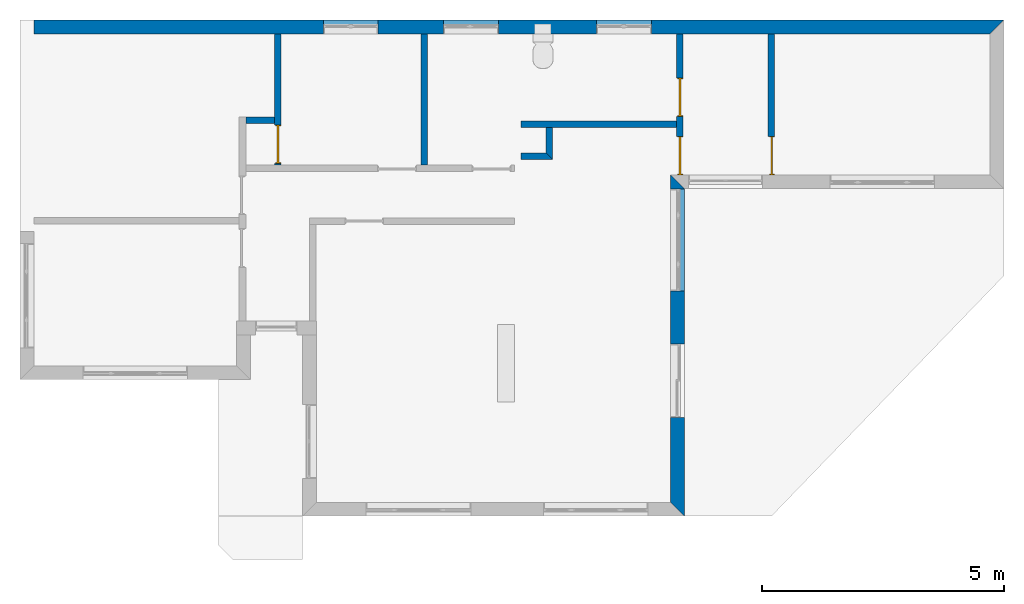
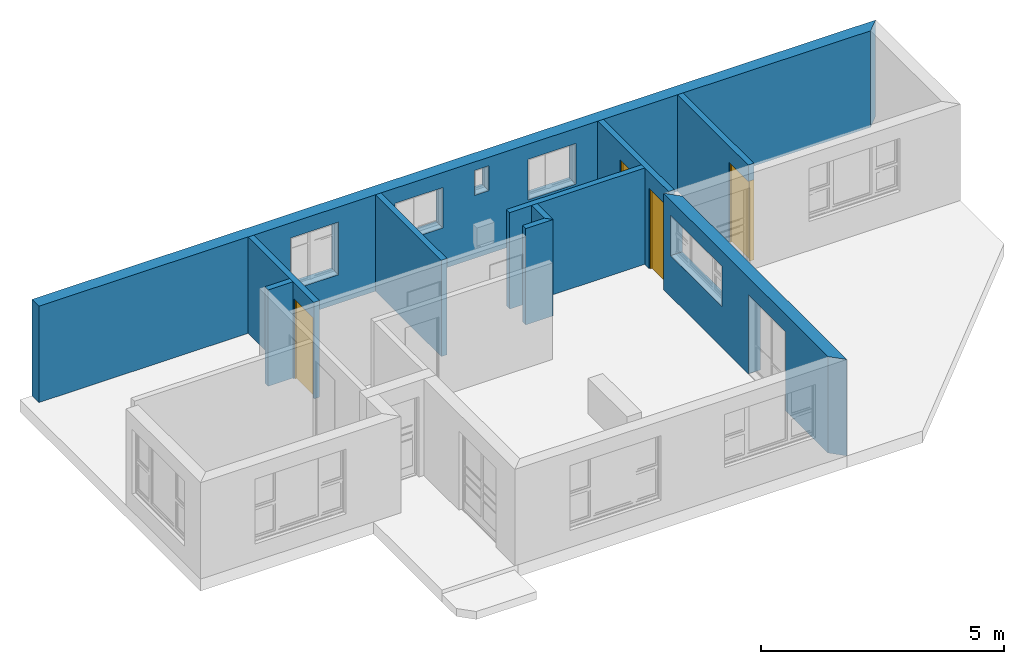
"""IFC4 building model written with IfcOpenShell, lengths in millimetres."""

from ifc_helpers import new_model, entity, si_unit, converted_unit, frame, origin_with_axes, origin_2d_with_axis, place, context, subcontext, project, spatial, line, indexed_curve, outline, extrude, clip, halfspace, polygons, source, transform, mapped, material, layer, layer_set, layer_usage, type_object, type_shapes, element, fill, save


model = new_model("IFC4")

# Units and contexts
model_context = context("Model", 3, precision=1e-05, world=origin_with_axes())
plan_context = context("Plan", 2, precision=1e-05, world=origin_2d_with_axis())
body_context = subcontext(model_context, "Body", "Model", "MODEL_VIEW")
ifc_project = project(units=[si_unit("VOLUMEUNIT", "CUBIC_METRE"), si_unit("LENGTHUNIT", "METRE", prefix="MILLI"), converted_unit("PLANEANGLEUNIT", "degree", entity("IfcReal", 0.0174532925199433), si_unit("PLANEANGLEUNIT", "RADIAN"), dimensions=[0, 0, 0, 0, 0, 0, 0]), si_unit("AREAUNIT", "SQUARE_METRE")], contexts=[model_context, plan_context])

# Site, building, storey
site_placement = place(None, origin_with_axes())
site = spatial("IfcSite", under=ifc_project, at=site_placement)
building_placement = place(site_placement, origin_with_axes())
building = spatial("IfcBuilding", under=site, at=building_placement, Name="Building")
storey_1_placement = place(building_placement, origin_with_axes())
storey_1 = spatial("IfcBuildingStorey", under=building, at=storey_1_placement, Name="EXISTING")

# Wall
ifc_material = material()
ifc_layer_1 = layer(ifc_material, 135.0)
ifc_layer_set_1 = layer_set([ifc_layer_1])
ifc_layer_usage_1 = layer_usage(ifc_layer_set_1, "AXIS2", "POSITIVE", 0.0)
wall_type_1 = type_object("IfcWallType", Name="WAL135", PredefinedType="NOTDEFINED", material=ifc_layer_set_1)
wall_1_placement = place(storey_1_placement, frame((10114.1204833984, 3521.66748046875, 0.0), z_axis=(0.0, 0.0, 1.0), x_axis=(0.999999999999993, 1.19209282445353e-07, 0.0)))
element("IfcWall", 1, at=wall_1_placement, inside=storey_1, type_object=wall_type_1, material=ifc_layer_usage_1, Name="Wall", context=body_context, shape_type="SweptSolid", body=[
    extrude(outline(indexed_curve([(0.0, 0.0), (0.0, 135.0), (3215.00111747473, 135.0), (3215.00111747473, 0.0), (0.0, 0.0)], self_intersect=False)), origin_with_axes(), (0.0, 0.0, 1.0), 2425.00019073486),
])

# Wall, opening, door
ifc_layer_usage_2 = layer_usage(ifc_layer_set_1, "AXIS2", "POSITIVE", 0.0)
wall_2_placement = place(storey_1_placement, frame((5009.11998748779, 5461.66658401489, 0.0), z_axis=(0.0, 0.0, 1.0), x_axis=(3.13916473260163e-07, -0.999999999999951, 0.0)))
wall_2 = element("IfcWall", 2, at=wall_2_placement, inside=storey_1, type_object=wall_type_1, material=ifc_layer_usage_2, Name="Wall", context=body_context, shape_type="SweptSolid", body=[
    extrude(outline(indexed_curve([(0.0, 0.0), (0.0, 135.0), (2715.00015357159, 135.0), (2715.00015357159, 0.0), (0.0, 0.0)], self_intersect=False)), origin_with_axes(), (0.0, 0.0, 1.0), 2425.00019073486),
])
shared_shape_1 = source(origin_with_axes(), body_context, "Body", "SweptSolid", [
    extrude(outline(indexed_curve([(0.0, 0.0), (800.001098632812, 0.0), (800.001098632812, 2015.00024414062), (0.0, 2015.00024414062)], segments=[line(1, 2, 3, 4, 1)])), frame((-1.78813922957488e-06, -600.0, 0.0), z_axis=(0.0, -1.0, 0.0), x_axis=(1.0, 0.0, 0.0)), (0.0, 0.0, -1.0), 1200.0),
])
opening_1_placement = place(wall_2_placement, frame((1885.00118255638, 0.000219627772857223, 0.0), z_axis=(0.0, 0.0, 1.0), x_axis=(1.0, 0.0, 0.0)))
opening_1 = element("IfcOpeningElement", 3, at=opening_1_placement, cuts=wall_2, Name="Opening", PredefinedType="OPENING", context=body_context, shape_type="MappedRepresentation", body=[
    mapped(shared_shape_1, transform((0.0, 0.0, 0.0), x_axis=(1.0, 0.0, 0.0), y_axis=(0.0, 1.0, 0.0), z_axis=(0.0, 0.0, 1.0), scale=1.0)),
])
door_type = type_object("IfcDoorType", OperationType="NOTDEFINED", PredefinedType="DOOR")
shared_shape_2 = source(origin_with_axes(), body_context, "Body", "Tessellation", [
    polygons([(0.000119209282274824, -53.7499732971191, 0.0), (20.0005760192871, -53.7499732971191, 0.0), (0.000119209282274824, -53.75, 1994.99987792969), (20.0005760192871, -53.75, 1994.99987792969), (0.000119209282274824, 56.2500038146973, 0.0), (20.0005760192871, 56.2500076293945, 0.0), (0.000119209282274824, 56.2499351501465, 1994.99987792969), (20.0005760192871, 56.249942779541, 1994.99987792969), (799.999328613281, -53.7499656677246, 1994.99987792969), (-0.0017881392268464, -53.75, 1994.99987792969), (799.999328613281, -53.7499656677246, 2015.00024414062), (799.999328613281, 56.2499809265137, 1994.99987792969), (-0.0017881392268464, 56.2499351501465, 1994.99987792969), (799.999328613281, 56.2499809265137, 2015.00024414062), (-0.0017881392268464, 56.2499351501465, 2014.99975585938), (-0.0017881392268464, -53.75, 2014.99975585938), (779.996948242188, -53.7499656677246, 0.0), (779.996948242188, -53.7499923706055, 1994.99987792969), (799.999328613281, -53.7499656677246, 0.0), (779.996948242188, 56.2499771118164, 0.0), (779.996948242188, 56.249942779541, 1994.99987792969), (799.999328613281, 56.2499809265137, 0.0), (799.999328613281, 56.2499465942383, 1994.99987792969), (799.999328613281, -53.7499923706055, 1994.99987792969), (779.998840332031, -23.7499713897705, 1994.99987792969), (779.996948242188, -23.749942779541, 9.99998950958252), (19.9986686706543, -23.749979019165, 1994.99987792969), (779.998840332031, 16.2500343322754, 1994.99987792969), (779.996948242188, 16.2500343322754, 9.99998950958252), (19.9986686706543, 16.2500305175781, 1994.99987792969), (19.9967613220215, 16.2500305175781, 9.99998950958252), (19.9967613220215, -23.7499465942383, 9.99998950958252)], [[[1, 2, 4, 3]], [[3, 4, 8, 7]], [[7, 8, 6, 5]], [[5, 6, 2, 1]], [[3, 7, 5, 1]], [[8, 4, 2, 6]], [[10, 13, 12, 9]], [[9, 11, 16, 10]], [[12, 14, 11, 9]], [[13, 15, 14, 12]], [[15, 16, 11, 14]], [[10, 16, 15, 13]], [[18, 21, 20, 17]], [[17, 19, 24, 18]], [[20, 22, 19, 17]], [[21, 23, 22, 20]], [[23, 24, 19, 22]], [[18, 24, 23, 21]], [[26, 29, 28, 25]], [[25, 27, 32, 26]], [[28, 30, 27, 25]], [[29, 31, 30, 28]], [[31, 32, 27, 30]], [[26, 32, 31, 29]]], closed=True),
])
type_shapes(door_type, [shared_shape_2])
door_1_placement = place(opening_1_placement, frame((2.47210905079953e-05, 78.7507526651812, 0.0), z_axis=(0.0, 0.0, 1.0), x_axis=(0.999999999999886, -4.76837158203095e-07, 0.0)))
door_1 = element("IfcDoor", 4, at=door_1_placement, inside=storey_1, type_object=door_type, Name="Door", context=body_context, shape_type="MappedRepresentation", body=[
    mapped(shared_shape_2, transform((0.0, 0.0, 0.0), x_axis=(1.0, 0.0, 0.0), y_axis=(0.0, 1.0, 0.0), z_axis=(0.0, 0.0, 1.0), scale=1.0)),
])
fill(opening_1, door_1)

# Wall
ifc_layer_usage_3 = layer_usage(ifc_layer_set_1, "AXIS2", "POSITIVE", 0.0)
wall_3_placement = place(storey_1_placement, frame((8039.11972045898, 5461.66706085205, 0.0), z_axis=(0.0, 0.0, 1.0), x_axis=(3.13916473260163e-07, -0.999999999999951, 0.0)))
element("IfcWall", 5, at=wall_3_placement, inside=storey_1, type_object=wall_type_1, material=ifc_layer_usage_3, Name="Wall", context=body_context, shape_type="SweptSolid", body=[
    extrude(outline(indexed_curve([(0.0, 0.0), (0.0, 135.0), (2715.00015357159, 135.0), (2715.00015357159, 0.0), (0.0, 0.0)], self_intersect=False)), origin_with_axes(), (0.0, 0.0, 1.0), 2425.00019073486),
])

# Wall, openings
ifc_layer_usage_4 = layer_usage(ifc_layer_set_1, "AXIS2", "POSITIVE", 0.0)
wall_4_placement = place(storey_1_placement, frame((13329.119682312, 5461.66706085205, 0.0), z_axis=(0.0, 0.0, 1.0), x_axis=(3.13916473260163e-07, -0.999999999999951, 0.0)))
wall_4 = element("IfcWall", 6, at=wall_4_placement, inside=storey_1, type_object=wall_type_1, material=ifc_layer_usage_4, Name="Wall", context=body_context, shape_type="SweptSolid", body=[
    extrude(outline(indexed_curve([(0.0, 0.0), (0.0, 135.0), (2920.00009693527, 135.0), (2920.00009693527, 0.0), (0.0, 0.0)], self_intersect=False)), origin_with_axes(), (0.0, 0.0, 1.0), 2425.00019073486),
])
opening_2_placement = place(wall_4_placement, frame((2120.00086789768, 73.6082881344458, 0.0), z_axis=(0.0, 0.0, 1.0), x_axis=(1.0, 0.0, 0.0)))
opening_2 = element("IfcOpeningElement", 7, at=opening_2_placement, cuts=wall_4, Name="Opening", PredefinedType="OPENING", context=body_context, shape_type="MappedRepresentation", body=[
    mapped(shared_shape_1, transform((0.0, 0.0, 0.0), x_axis=(1.0, 0.0, 0.0), y_axis=(0.0, 1.0, 0.0), z_axis=(0.0, 0.0, 1.0), scale=1.0)),
])
opening_3_placement = place(wall_4_placement, frame((915.003807216657, 78.7497771987811, 0.0), z_axis=(0.0, 0.0, 1.0), x_axis=(1.0, 0.0, 0.0)))
opening_3 = element("IfcOpeningElement", 8, at=opening_3_placement, cuts=wall_4, Name="Opening", PredefinedType="OPENING", context=body_context, shape_type="MappedRepresentation", body=[
    mapped(shared_shape_1, transform((0.0, 0.0, 0.0), x_axis=(1.0, 0.0, 0.0), y_axis=(0.0, 1.0, 0.0), z_axis=(0.0, 0.0, 1.0), scale=1.0)),
])

# Storey
storey_2_placement = place(building_placement, origin_with_axes())
storey_2 = spatial("IfcBuildingStorey", under=building, at=storey_2_placement, Name="DEMO")

# Door
door_2_placement = place(opening_2_placement, frame((0.000948117118149128, 0.000398473892104789, 0.0), z_axis=(0.0, 0.0, 1.0), x_axis=(0.999999999999886, -4.76837158203095e-07, 0.0)))
door_2 = element("IfcDoor", 9, at=door_2_placement, inside=storey_2, type_object=door_type, Name="Door", context=body_context, shape_type="MappedRepresentation", body=[
    mapped(shared_shape_2, transform((0.0, 0.0, 0.0), x_axis=(1.0, 0.0, 0.0), y_axis=(0.0, 1.0, 0.0), z_axis=(0.0, 0.0, 1.0), scale=1.0)),
])

fill(opening_2, door_2)

door_3_placement = place(opening_3_placement, frame((0.000947729319911161, 0.00149959204698291, 0.0), z_axis=(0.0, 0.0, 1.0), x_axis=(0.999999999999886, -4.76837158203095e-07, 0.0)))
door_3 = element("IfcDoor", 10, at=door_3_placement, inside=storey_1, type_object=door_type, Name="Door", context=body_context, shape_type="MappedRepresentation", body=[
    mapped(shared_shape_2, transform((0.0, 0.0, 0.0), x_axis=(1.0, 0.0, 0.0), y_axis=(0.0, 1.0, 0.0), z_axis=(0.0, 0.0, 1.0), scale=1.0)),
])

fill(opening_3, door_3)

# Wall, opening, door
ifc_layer_usage_5 = layer_usage(ifc_layer_set_1, "AXIS2", "POSITIVE", 0.0)
wall_5_placement = place(storey_1_placement, frame((15224.1201400757, 5461.66706085205, 0.0), z_axis=(0.0, 0.0, 1.0), x_axis=(3.13916473260163e-07, -0.999999999999951, 0.0)))
wall_5 = element("IfcWall", 11, at=wall_5_placement, inside=storey_1, type_object=wall_type_1, material=ifc_layer_usage_5, Name="Wall", context=body_context, shape_type="SweptSolid", body=[
    extrude(outline(indexed_curve([(0.0, 0.0), (0.0, 135.0), (2920.00009693527, 135.0), (2920.00009693527, 0.0), (0.0, 0.0)], self_intersect=False)), origin_with_axes(), (0.0, 0.0, 1.0), 2425.00019073486),
])
opening_4_placement = place(wall_5_placement, frame((2120.00274658224, 0.000128114788111588, 0.0), z_axis=(0.0, 0.0, 1.0), x_axis=(1.0, 0.0, 0.0)))
opening_4 = element("IfcOpeningElement", 12, at=opening_4_placement, cuts=wall_5, Name="Opening", PredefinedType="OPENING", context=body_context, shape_type="MappedRepresentation", body=[
    mapped(shared_shape_1, transform((0.0, 0.0, 0.0), x_axis=(1.0, 0.0, 0.0), y_axis=(0.0, 1.0, 0.0), z_axis=(0.0, 0.0, 1.0), scale=1.0)),
])
door_4_placement = place(opening_4_placement, frame((0.00193206973220228, 78.7507704066837, 0.0), z_axis=(0.0, 0.0, 1.0), x_axis=(0.999999999999886, -4.76837158203095e-07, 0.0)))
door_4 = element("IfcDoor", 13, at=door_4_placement, inside=storey_1, type_object=door_type, Name="Door", context=body_context, shape_type="MappedRepresentation", body=[
    mapped(shared_shape_2, transform((0.0, 0.0, 0.0), x_axis=(1.0, 0.0, 0.0), y_axis=(0.0, 1.0, 0.0), z_axis=(0.0, 0.0, 1.0), scale=1.0)),
])
fill(opening_4, door_4)

# Walls
ifc_layer_usage_6 = layer_usage(ifc_layer_set_1, "AXIS2", "POSITIVE", 0.0)
wall_6_placement = place(storey_1_placement, frame((4419.11888122559, 3606.66704177856, 0.0), z_axis=(0.0, 0.0, 1.0), x_axis=(0.999999999999993, 1.19209282445353e-07, 0.0)))
element("IfcWall", 14, at=wall_6_placement, inside=storey_1, type_object=wall_type_1, material=ifc_layer_usage_6, Name="Wall", context=body_context, shape_type="SweptSolid", body=[
    extrude(outline(indexed_curve([(0.0, 0.0), (0.0, 135.0), (590.001571459213, 135.0), (590.001571459213, 0.0), (0.0, 0.0)], self_intersect=False)), origin_with_axes(), (0.0, 0.0, 1.0), 2425.00019073486),
])
ifc_layer_usage_7 = layer_usage(ifc_layer_set_1, "AXIS2", "POSITIVE", 0.0)
wall_7_placement = place(storey_1_placement, frame((10114.1214370728, 2861.6669178009, 0.0), z_axis=(0.0, 0.0, 1.0), x_axis=(0.999999999999993, 1.19209282445353e-07, 0.0)))
element("IfcWall", 15, at=wall_7_placement, inside=storey_1, type_object=wall_type_1, material=ifc_layer_usage_7, Name="Wall", context=body_context, shape_type="Clipping", body=[
    clip(extrude(outline(indexed_curve([(0.0, 0.0), (0.0, 135.0), (654.999722706394, 135.0), (654.999722706394, 0.0), (0.0, 0.0)], self_intersect=False)), origin_with_axes(), (0.0, 0.0, 1.0), 2425.00019073486), halfspace(frame((654.999732971191, 0.0, 0.0), z_axis=(0.70710676908493, 0.70710676908493, 0.0), x_axis=(0.707106781186547, -0.707106781186547, 0.0)), False)),
])
ifc_layer_usage_8 = layer_usage(ifc_layer_set_1, "AXIS2", "POSITIVE", 0.0)
wall_8_placement = place(storey_1_placement, frame((10769.1211700439, 2861.66763305664, 0.0), z_axis=(0.0, 0.0, 1.0), x_axis=(3.13916473260163e-07, 0.999999999999951, 0.0)))
element("IfcWall", 16, at=wall_8_placement, inside=storey_1, type_object=wall_type_1, material=ifc_layer_usage_8, Name="Wall", context=body_context, shape_type="Clipping", body=[
    clip(extrude(outline(indexed_curve([(0.0, 0.0), (0.0, 135.0), (660.000325585776, 135.0), (660.000325585776, 0.0), (0.0, 0.0)], self_intersect=False)), origin_with_axes(), (0.0, 0.0, 1.0), 2425.00019073486), halfspace(frame((0.000121499851957196, 0.000466797700937605, 0.0), z_axis=(-0.70710700750351, 0.707106530666351, 0.0), x_axis=(0.707106542767924, 0.70710701960509, 0.0)), False)),
])

# Wall, openings
ifc_layer_2 = layer(ifc_material, 285.0, Name="brick")
ifc_layer_set_2 = layer_set([ifc_layer_2])
ifc_layer_usage_9 = layer_usage(ifc_layer_set_2, "AXIS2", "POSITIVE", 0.0)
wall_type_2 = type_object("IfcWallType", Name="285mm Wall", PredefinedType="STANDARD", material=ifc_layer_set_2)
wall_9_placement = place(storey_1_placement, frame((34.1207385063171, 5461.66706085205, 0.0), z_axis=(0.0, 0.0, 1.0), x_axis=(0.999999999999993, 1.19209282445353e-07, 0.0)))
wall_9 = element("IfcWall", 17, at=wall_9_placement, inside=storey_1, type_object=wall_type_2, material=ifc_layer_usage_9, Name="Wall", context=body_context, shape_type="Clipping", body=[
    clip(extrude(outline(indexed_curve([(0.0, 0.0), (0.0, 285.0), (20070.0015485353, 285.0), (20070.0015485353, 0.0), (0.0, 0.0)], self_intersect=False)), origin_with_axes(), (0.0, 0.0, 1.0), 2425.00019073486), halfspace(frame((19785.0017547607, 2.1562527763308e-05, 0.0), z_axis=(0.707106709480286, -0.707106828689575, 0.0), x_axis=(-0.707106840791191, -0.707106721581899, 0.0)), False)),
])
shared_shape_3 = source(origin_with_axes(), body_context, "Body", "SweptSolid", [
    extrude(outline(indexed_curve([(0.0, 0.0), (340.000091552734, 0.0), (340.000091552734, 625.0), (0.0, 625.0)], segments=[line(1, 2, 3, 4, 1)])), frame((1.19209282445354e-07, -600.0, 0.0), z_axis=(0.0, -1.0, 0.0), x_axis=(1.0, 0.0, 0.0)), (0.0, 0.0, -1.0), 1200.0),
])
opening_5_placement = place(wall_9_placement, frame((10361.9993493649, 138.076500654373, 1585.00003814697), z_axis=(0.0, 0.0, 1.0), x_axis=(1.0, 0.0, 0.0)))
element("IfcOpeningElement", 18, at=opening_5_placement, cuts=wall_9, PredefinedType="OPENING", context=body_context, shape_type="MappedRepresentation", body=[
    mapped(shared_shape_3, transform((0.0, 0.0, 0.0), x_axis=(1.0, 0.0, 0.0), y_axis=(0.0, 1.0, 0.0), z_axis=(0.0, 0.0, 1.0), scale=1.0)),
])
shared_shape_4 = source(origin_with_axes(), body_context, "Body", "SweptSolid", [
    extrude(outline(indexed_curve([(0.0, 0.0), (1135.00012207031, 0.0), (1135.00012207031, 1014.99981689453), (0.0, 1014.99981689453)], segments=[line(1, 2, 3, 4, 1)])), frame((1.19209282445354e-07, -600.0, 0.0), z_axis=(0.0, -1.0, 0.0), x_axis=(1.0, 0.0, 0.0)), (0.0, 0.0, -1.0), 1200.0),
])
opening_6_placement = place(wall_9_placement, frame((8475.00021959052, 142.058315873181, 1030.00020980835), z_axis=(0.0, 0.0, 1.0), x_axis=(1.0, 0.0, 0.0)))
element("IfcOpeningElement", 19, at=opening_6_placement, cuts=wall_9, PredefinedType="OPENING", context=body_context, shape_type="MappedRepresentation", body=[
    mapped(shared_shape_4, transform((0.0, 0.0, 0.0), x_axis=(1.0, 0.0, 0.0), y_axis=(0.0, 1.0, 0.0), z_axis=(0.0, 0.0, 1.0), scale=1.0)),
])
shared_shape_5 = source(origin_with_axes(), body_context, "Body", "SweptSolid", [
    extrude(outline(indexed_curve([(0.0, 0.0), (1135.0, 0.0), (1135.0, 1321.99987792969), (0.0, 1321.99987792969)], segments=[line(1, 2, 3, 4, 1)])), frame((0.0, -600.0, -1.02445474325918e-08), z_axis=(0.0, -1.0, 0.0), x_axis=(1.0, 0.0, 0.0)), (0.0, 0.0, -1.0), 1200.0),
])
opening_7_placement = place(wall_9_placement, frame((5989.99865055079, 99.9991905691289, 723.000049591064), z_axis=(0.0, 0.0, 1.0), x_axis=(1.0, 0.0, 0.0)))
element("IfcOpeningElement", 20, at=opening_7_placement, cuts=wall_9, PredefinedType="OPENING", context=body_context, shape_type="MappedRepresentation", body=[
    mapped(shared_shape_5, transform((0.0, 0.0, 0.0), x_axis=(1.0, 0.0, 0.0), y_axis=(0.0, 1.0, 0.0), z_axis=(0.0, 0.0, 1.0), scale=1.0)),
])
shared_shape_6 = source(origin_with_axes(), body_context, "Body", "SweptSolid", [
    extrude(outline(indexed_curve([(0.0, 0.0), (1135.00024414062, 0.0), (1135.00024414062, 1019.99993896484), (0.0, 1019.99993896484)], segments=[line(1, 2, 3, 4, 1)])), frame((0.0, -600.0, -9.31322485797637e-09), z_axis=(0.0, -1.0, 0.0), x_axis=(1.0, 0.0, 0.0)), (0.0, 0.0, -1.0), 1200.0),
])
opening_8_placement = place(wall_9_placement, frame((11639.9992275636, 140.332741737542, 1025.00009536743), z_axis=(0.0, 0.0, 1.0), x_axis=(1.0, 0.0, 0.0)))
element("IfcOpeningElement", 21, at=opening_8_placement, cuts=wall_9, PredefinedType="OPENING", context=body_context, shape_type="MappedRepresentation", body=[
    mapped(shared_shape_6, transform((0.0, 0.0, 0.0), x_axis=(1.0, 0.0, 0.0), y_axis=(0.0, 1.0, 0.0), z_axis=(0.0, 0.0, 1.0), scale=1.0)),
])

ifc_layer_usage_10 = layer_usage(ifc_layer_set_2, "AXIS2", "POSITIVE", 0.0)
wall_10_placement = place(storey_1_placement, frame((13494.119644165, -4518.33248138428, 0.0), z_axis=(0.0, 0.0, 1.0), x_axis=(3.13916473260163e-07, 0.999999999999951, 0.0)))
wall_10 = element("IfcWall", 22, at=wall_10_placement, inside=storey_1, type_object=wall_type_2, material=ifc_layer_usage_10, Name="Wall", context=body_context, shape_type="Clipping", body=[
    clip(clip(extrude(outline(indexed_curve([(0.0, 0.0), (0.0, 285.0), (7060.00143769791, 285.0), (7060.00143769791, 0.0), (0.0, 0.0)], self_intersect=False)), origin_with_axes(), (0.0, 0.0, 1.0), 2425.00019073486), halfspace(frame((2.32475940720178e-05, 5.74426053390198e-05, 0.0), z_axis=(-0.707106709480286, 0.707106828689575, 0.0), x_axis=(0.707106840791191, 0.707106721581899, 0.0)), False)), halfspace(frame((6775.00104904175, 0.000276878381555434, 0.0), z_axis=(0.70710700750351, -0.707106530666351, 0.0), x_axis=(-0.707106542767924, -0.70710701960509, 0.0)), False)),
])
shared_shape_7 = source(origin_with_axes(), body_context, "Body", "SweptSolid", [
    extrude(outline(indexed_curve([(0.0, 0.0), (2110.00024414062, 0.0), (2110.00024414062, 1014.99993896484), (0.0, 1014.99993896484)], segments=[line(1, 2, 3, 4, 1)])), frame((1.19209282445354e-07, -600.0, 0.0), z_axis=(0.0, -1.0, 0.0), x_axis=(1.0, 0.0, 0.0)), (0.0, 0.0, -1.0), 1200.0),
])
opening_9_placement = place(wall_10_placement, frame((6771.17128867833, 136.111477694053, 1030.00009059906), z_axis=(0.0, 0.0, 1.0), x_axis=(-0.999999999999999, -3.17864987664478e-08, 0.0)))
element("IfcOpeningElement", 23, at=opening_9_placement, cuts=wall_10, PredefinedType="OPENING", context=body_context, shape_type="MappedRepresentation", body=[
    mapped(shared_shape_7, transform((0.0, 0.0, 0.0), x_axis=(1.0, 0.0, 0.0), y_axis=(0.0, 1.0, 0.0), z_axis=(0.0, 0.0, 1.0), scale=1.0)),
])
shared_shape_8 = source(origin_with_axes(), body_context, "Body", "SweptSolid", [
    extrude(outline(indexed_curve([(0.0, 0.0), (1525.00085449219, 0.0), (1525.00085449219, 1990.0), (0.0, 1990.0)], segments=[line(1, 2, 3, 4, 1)])), frame((-3.57627840230634e-07, -600.0, 0.0), z_axis=(0.0, -1.0, 0.0), x_axis=(1.0, 0.0, 0.0)), (0.0, 0.0, -1.0), 1200.0),
])
opening_10_placement = place(wall_10_placement, frame((3565.00013056336, 146.110700105945, 0.0), z_axis=(0.0, 0.0, 1.0), x_axis=(-0.999999999999999, -3.17864987664478e-08, 0.0)))
element("IfcOpeningElement", 24, at=opening_10_placement, cuts=wall_10, PredefinedType="OPENING", context=body_context, shape_type="MappedRepresentation", body=[
    mapped(shared_shape_8, transform((0.0, 0.0, 0.0), x_axis=(1.0, 0.0, 0.0), y_axis=(0.0, 1.0, 0.0), z_axis=(0.0, 0.0, 1.0), scale=1.0)),
])

save(model, "model.ifc")
